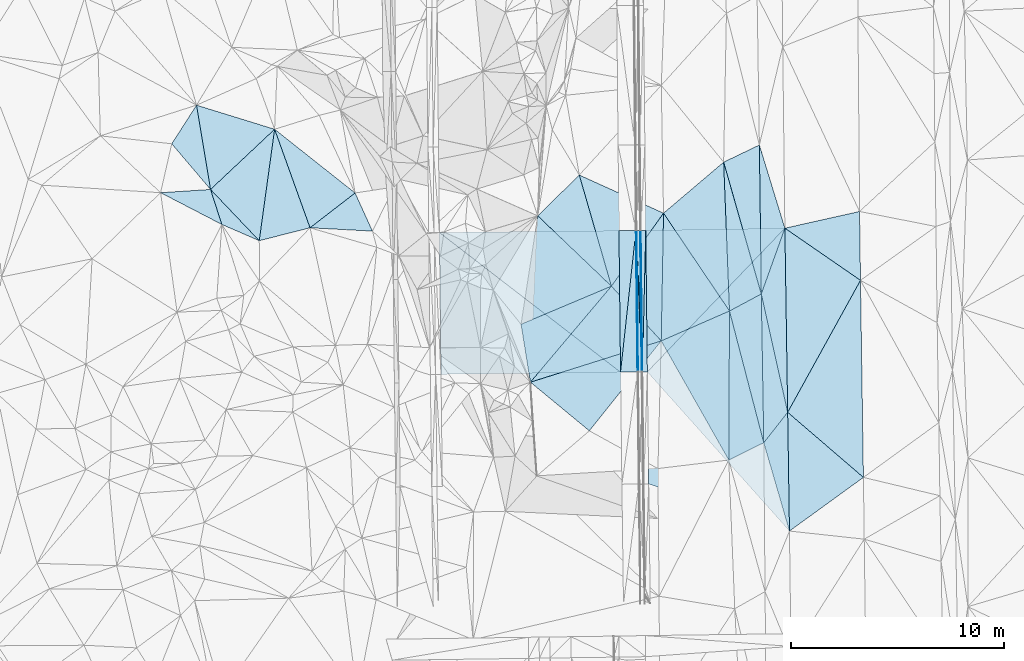
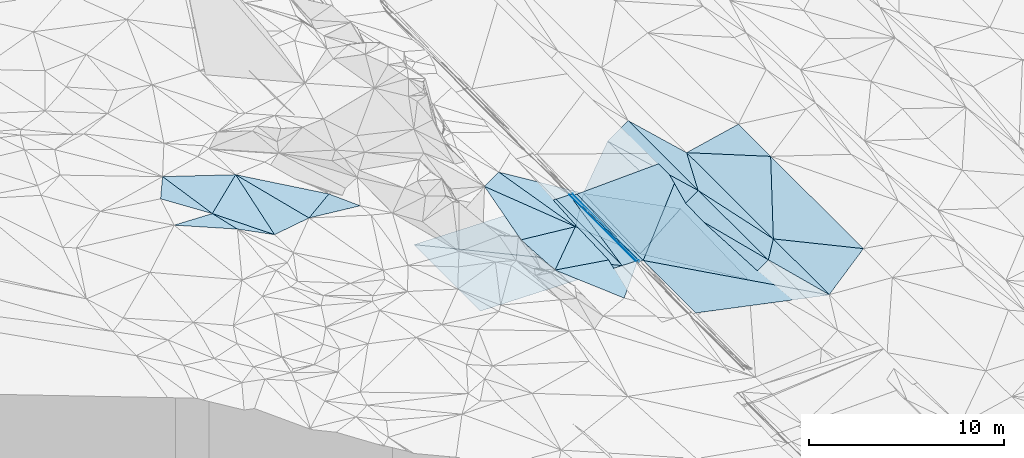
# One storey, part 16 of 275: 45 plates.
"""IFC2X3 building model written with IfcOpenShell, lengths in millimetres."""

from ifc_helpers import new_model, si_unit, frame, origin_with_axes, place, context, subcontext, project, spatial, polyline, outline, extrude, material, type_object, element, save


model = new_model("IFC2X3")

# Units and contexts
model_context = context("Model", 3, precision=1e-05, world=origin_with_axes())
body_context = subcontext(model_context, "Body", "Model", "MODEL_VIEW")
ifc_project = project(units=[si_unit("LENGTHUNIT", "METRE", prefix="MILLI"), si_unit("AREAUNIT", "SQUARE_METRE"), si_unit("VOLUMEUNIT", "CUBIC_METRE"), si_unit("MASSUNIT", "GRAM", prefix="KILO"), si_unit("TIMEUNIT", "SECOND"), si_unit("PLANEANGLEUNIT", "RADIAN"), si_unit("SOLIDANGLEUNIT", "STERADIAN"), si_unit("THERMODYNAMICTEMPERATUREUNIT", "DEGREE_CELSIUS"), si_unit("LUMINOUSINTENSITYUNIT", "LUMEN")], contexts=[model_context])

# Site, building, storey
site_placement = place(None, origin_with_axes())
site = spatial("IfcSite", under=ifc_project, at=site_placement, CompositionType="ELEMENT")
building_placement = place(site_placement, origin_with_axes())
building = spatial("IfcBuilding", under=site, at=building_placement, Name="Undefined", CompositionType="ELEMENT")
storey_placement = place(building_placement, origin_with_axes())
storey = spatial("IfcBuildingStorey", under=building, at=storey_placement, Name="Undefined", CompositionType="ELEMENT", Elevation=0.0)

# Plates
ifc_material = material()
plate_type_1 = type_object("IfcPlateType", PredefinedType="NOTDEFINED")
plate_1_placement = place(storey_placement, frame((-114015.364922591, 20772.4693420443, 46089.5039279863), z_axis=(-0.124564467724949, 0.0143597210554307, -0.99210760091414), x_axis=(-0.644770726207138, 0.758826841202952, 0.091937672889135)))
element("IfcPlate", 1, at=plate_1_placement, inside=storey, type_object=plate_type_1, material=ifc_material, Name="00", context=body_context, shape_type="SweptSolid", body=[
    extrude(outline(polyline([(0.0, 0.0), (2828.0029296875, 3.94356902688742e-09), (3443.91455078125, 2071.509765625), (0.0, 0.0)])), frame((-8.85201319254618e-08, 2.18876761149539e-07, -0.5000001331573), z_axis=(0.0, 0.0, 1.0), x_axis=(1.0, 0.0, 0.0)), (0.0, 0.0, 1.0), 1.0),
])
plate_type_2 = type_object("IfcPlateType", PredefinedType="NOTDEFINED")
plate_2_placement = place(storey_placement, frame((-93709.8882366682, 12193.5228893056, 41161.9217423104), z_axis=(-0.970128997320581, -0.00579860174768376, -0.242520318273614), x_axis=(-0.015702742113764, 0.999118731297531, 0.038925372965714)))
element("IfcPlate", 2, at=plate_2_placement, inside=storey, type_object=plate_type_2, material=ifc_material, Name="00_PR", context=body_context, shape_type="SweptSolid", body=[
    extrude(outline(polyline([(0.0, 0.0), (6661.51611328125, -4.67844074591994e-09), (6656.88037109375, 123.606216430664), (0.0, 0.0)])), frame((-8.85201319254618e-08, 2.18876761149539e-07, -0.5000001331573), z_axis=(0.0, 0.0, 1.0), x_axis=(1.0, 0.0, 0.0)), (0.0, 0.0, 1.0), 1.0),
])
plate_3_placement = place(storey_placement, frame((-93739.8481940446, 12192.151688232, 41281.9218577962), z_axis=(-0.970186715297732, -0.00580851785171614, -0.242289080604477), x_axis=(-0.0112096931076123, 0.999718314898496, 0.0209196949534378)))
element("IfcPlate", 3, at=plate_3_placement, inside=storey, type_object=plate_type_2, material=ifc_material, Name="00_PR", context=body_context, shape_type="SweptSolid", body=[
    extrude(outline(polyline([(0.0, 0.0), (6658.892578125, -9.24046617001295e-10), (-1.47539520263672, 123.682258605957), (0.0, 0.0)])), frame((-8.85201319254618e-08, 2.18876761149539e-07, -0.5000001331573), z_axis=(0.0, 0.0, 1.0), x_axis=(1.0, 0.0, 0.0)), (0.0, 0.0, 1.0), 1.0),
])
plate_type_3 = type_object("IfcPlateType", PredefinedType="NOTDEFINED")
plate_4_placement = place(storey_placement, frame((-94014.0067303804, 18847.0490866945, 41421.4452097669), z_axis=(-0.0202134344117027, 0.0206895906659804, -0.999581591420809), x_axis=(0.999743205173964, 0.0106622311027607, -0.0199960130126212)))
element("IfcPlate", 4, at=plate_4_placement, inside=storey, type_object=plate_type_3, material=ifc_material, Name="00_PR", context=body_context, shape_type="SweptSolid", body=[
    extrude(outline(polyline([(0.0, 0.0), (30.0059814453125, -3.63797880709171e-11), (36.4389686584473, 6659.0771484375), (0.0, 0.0)])), frame((-8.85201319254618e-08, 2.18876761149539e-07, -0.5000001331573), z_axis=(0.0, 0.0, 1.0), x_axis=(1.0, 0.0, 0.0)), (0.0, 0.0, 1.0), 1.0),
])
plate_5_placement = place(storey_placement, frame((-93909.3611444638, 12190.1645919995, 41281.5432118689), z_axis=(-0.020236435741365, 0.0206892206620344, -0.999581133683946), x_axis=(-0.999730993002964, -0.011751785107922, 0.0199959289877928)))
element("IfcPlate", 5, at=plate_5_placement, inside=storey, type_object=plate_type_3, material=ifc_material, Name="00_PR", context=body_context, shape_type="SweptSolid", body=[
    extrude(outline(polyline([(0.0, 0.0), (30.0061073303223, -1.96450855582953e-10), (29.184642791748, 6659.11279296875), (0.0, 0.0)])), frame((-8.85201319254618e-08, 2.18876761149539e-07, -0.5000001331573), z_axis=(0.0, 0.0, 1.0), x_axis=(1.0, 0.0, 0.0)), (0.0, 0.0, 1.0), 1.0),
])
plate_type_4 = type_object("IfcPlateType", PredefinedType="NOTDEFINED")
plate_6_placement = place(storey_placement, frame((-94739.3039393407, 12180.3996695704, 41298.1432095314), z_axis=(-0.020236435741365, 0.0206892206620344, -0.999581133683946), x_axis=(0.108138377913419, 0.993965859161828, 0.018383743986026)))
element("IfcPlate", 6, at=plate_6_placement, inside=storey, type_object=plate_type_4, material=ifc_material, Name="00_PR", context=body_context, shape_type="SweptSolid", body=[
    extrude(outline(polyline([(0.0, 0.0), (6707.12109375, -9.16770659387112e-10), (95.5660781860352, 794.432739257813), (0.0, 0.0)])), frame((-8.85201319254618e-08, 2.18876761149539e-07, -0.5000001331573), z_axis=(0.0, 0.0, 1.0), x_axis=(1.0, 0.0, 0.0)), (0.0, 0.0, 1.0), 1.0),
])
plate_7_placement = place(storey_placement, frame((-94014.0067303804, 18847.0490866945, 41421.4452097669), z_axis=(-0.0202142278372576, 0.0206867028955279, -0.999581635143551), x_axis=(-0.108138377915694, -0.993965859161573, -0.0183837439864522)))
element("IfcPlate", 7, at=plate_7_placement, inside=storey, type_object=plate_type_4, material=ifc_material, Name="00_PR", context=body_context, shape_type="SweptSolid", body=[
    extrude(outline(polyline([(0.0, 0.0), (6707.12109375, -9.16770659387112e-10), (94.6877517700195, 794.537475585938), (0.0, 0.0)])), frame((-8.85201319254618e-08, 2.18876761149539e-07, -0.5000001331573), z_axis=(0.0, 0.0, 1.0), x_axis=(1.0, 0.0, 0.0)), (0.0, 0.0, 1.0), 1.0),
])
plate_type_5 = type_object("IfcPlateType", PredefinedType="NOTDEFINED")
plate_8_placement = place(storey_placement, frame((-93554.0065118289, 18851.9525804362, 41308.3453783009), z_axis=(0.0324249764352489, 0.0212743317926748, -0.99924772889907), x_axis=(0.0112097451260177, -0.99971829535616, -0.0209206009565716)))
element("IfcPlate", 8, at=plate_8_placement, inside=storey, type_object=plate_type_5, material=ifc_material, Name="00_PR", context=body_context, shape_type="SweptSolid", body=[
    extrude(outline(polyline([(0.0, 0.0), (6658.60400390625, 7.02857505530119e-09), (6657.86962890625, 230.148956298828), (0.0, 0.0)])), frame((-8.85201319254618e-08, 2.18876761149539e-07, -0.5000001331573), z_axis=(0.0, 0.0, 1.0), x_axis=(1.0, 0.0, 0.0)), (0.0, 0.0, 1.0), 1.0),
])
plate_9_placement = place(storey_placement, frame((-93783.9955541894, 18849.688672733, 41300.845377649), z_axis=(0.0323763452633119, 0.0212755018201682, -0.999249280855228), x_axis=(0.999420342391402, 0.00983784111357759, 0.0325913500253779)))
element("IfcPlate", 9, at=plate_9_placement, inside=storey, type_object=plate_type_5, material=ifc_material, Name="00_PR", context=body_context, shape_type="SweptSolid", body=[
    extrude(outline(polyline([(0.0, 0.0), (230.122406005859, -9.27684595808387e-10), (4.54311275482178, 6658.0263671875), (0.0, 0.0)])), frame((-8.85201319254618e-08, 2.18876761149539e-07, -0.5000001331573), z_axis=(0.0, 0.0, 1.0), x_axis=(1.0, 0.0, 0.0)), (0.0, 0.0, 1.0), 1.0),
])
plate_type_6 = type_object("IfcPlateType", PredefinedType="NOTDEFINED")
plate_10_placement = place(storey_placement, frame((-111002.348097839, 23602.4211123626, 45749.5039753553), z_axis=(-0.125310474385731, 0.0142325221932643, -0.992015483912041), x_axis=(-0.726450165524312, -0.682312394449298, 0.0819753218387428)))
element("IfcPlate", 10, at=plate_10_placement, inside=storey, type_object=plate_type_6, material=ifc_material, Name="00", context=body_context, shape_type="SweptSolid", body=[
    extrude(outline(polyline([(0.0, 0.0), (4147.58984375, -1.83208612725139e-08), (1933.84606933594, 3354.2568359375), (0.0, 0.0)])), frame((-8.85201319254618e-08, 2.18876761149539e-07, -0.5000001331573), z_axis=(0.0, 0.0, 1.0), x_axis=(1.0, 0.0, 0.0)), (0.0, 0.0, 1.0), 1.0),
])
plate_type_7 = type_object("IfcPlateType", PredefinedType="NOTDEFINED")
plate_11_placement = place(storey_placement, frame((-89651.0841865646, 8051.67344498103, 41150.5160623505), z_axis=(0.250479311664303, 0.0229576087276333, -0.967849710765926), x_axis=(-0.490462221541969, 0.864940847921323, -0.106414937096531)))
element("IfcPlate", 11, at=plate_11_placement, inside=storey, type_object=plate_type_7, material=ifc_material, Name="00", context=body_context, shape_type="SweptSolid", body=[
    extrude(outline(polyline([(0.0, 0.0), (6474.65478515625, -1.96523615159094e-08), (6024.47998046875, 3580.78173828125), (0.0, 0.0)])), frame((-8.85201319254618e-08, 2.18876761149539e-07, -0.5000001331573), z_axis=(0.0, 0.0, 1.0), x_axis=(1.0, 0.0, 0.0)), (0.0, 0.0, 1.0), 1.0),
])
plate_type_8 = type_object("IfcPlateType", PredefinedType="NOTDEFINED")
plate_12_placement = place(storey_placement, frame((-94739.3039393407, 12180.3996695704, 41298.1432095314), z_axis=(-0.0202365669105856, 0.0206577431224442, -0.999581782051254), x_axis=(-0.999730851009232, -0.0117629081194409, 0.0199964880149204)))
element("IfcPlate", 12, at=plate_12_placement, inside=storey, type_object=plate_type_8, material=ifc_material, Name="00_PR", context=body_context, shape_type="SweptSolid", body=[
    extrude(outline(polyline([(0.0, 0.0), (8444.1826171875, 4.79940354125574e-08), (8443.1376953125, 6669.33447265625), (0.0, 0.0)])), frame((-8.85201319254618e-08, 2.18876761149539e-07, -0.5000001331573), z_axis=(0.0, 0.0, 1.0), x_axis=(1.0, 0.0, 0.0)), (0.0, 0.0, 1.0), 1.0),
])
plate_type_9 = type_object("IfcPlateType", PredefinedType="NOTDEFINED")
plate_13_placement = place(storey_placement, frame((-103255.832350594, 18748.533567026, 41606.3002094753), z_axis=(-0.0202142278372576, 0.0206867028955279, -0.999581635143551), x_axis=(0.99974324254313, 0.0106569761117896, -0.0199969460043807)))
element("IfcPlate", 13, at=plate_13_placement, inside=storey, type_object=plate_type_9, material=ifc_material, Name="00_PR", context=body_context, shape_type="SweptSolid", body=[
    extrude(outline(polyline([(0.0, 0.0), (8444.0390625, 5.16338332090527e-08), (8450.5078125, 6659.994140625), (0.0, 0.0)])), frame((-8.85201319254618e-08, 2.18876761149539e-07, -0.5000001331573), z_axis=(0.0, 0.0, 1.0), x_axis=(1.0, 0.0, 0.0)), (0.0, 0.0, 1.0), 1.0),
])
plate_type_10 = type_object("IfcPlateType", PredefinedType="NOTDEFINED")
plate_14_placement = place(storey_placement, frame((-93739.3632111408, 12192.1650490318, 41281.543111635), z_axis=(-0.000223052062595147, 0.0209185094404313, -0.999781159159627), x_axis=(-0.0367256471119653, 0.999106546124247, 0.0209125879767624)))
element("IfcPlate", 14, at=plate_14_placement, inside=storey, type_object=plate_type_10, material=ifc_material, Name="00_PR", context=body_context, shape_type="SweptSolid", body=[
    extrude(outline(polyline([(0.0, 0.0), (6661.15576171875, 1.97906047105789e-09), (6656.7236328125, 169.942993164063), (0.0, 0.0)])), frame((-8.85201319254618e-08, 2.18876761149539e-07, -0.5000001331573), z_axis=(0.0, 0.0, 1.0), x_axis=(1.0, 0.0, 0.0)), (0.0, 0.0, 1.0), 1.0),
])
plate_15_placement = place(storey_placement, frame((-93739.3632111408, 12192.1650490318, 41281.543111635), z_axis=(-0.000246149900615018, 0.0209176607376323, -0.999781171496789), x_axis=(-0.999930769399473, -0.0117667501111672, -2.73062899398761e-11)))
element("IfcPlate", 15, at=plate_15_placement, inside=storey, type_object=plate_type_10, material=ifc_material, Name="00_PR", context=body_context, shape_type="SweptSolid", body=[
    extrude(outline(polyline([(0.0, 0.0), (169.999694824219, 9.24046617001295e-10), (166.308197021484, 6659.0791015625), (0.0, 0.0)])), frame((-8.85201319254618e-08, 2.18876761149539e-07, -0.5000001331573), z_axis=(0.0, 0.0, 1.0), x_axis=(1.0, 0.0, 0.0)), (0.0, 0.0, 1.0), 1.0),
])
plate_type_11 = type_object("IfcPlateType", PredefinedType="NOTDEFINED")
plate_16_placement = place(storey_placement, frame((-87013.0404522369, 18951.1289030204, 41504.7893355039), z_axis=(0.0295354950647093, 0.0213940997876386, -0.999334752235486), x_axis=(0.0151458611024018, -0.999665720009021, -0.0209535469625894)))
element("IfcPlate", 16, at=plate_16_placement, inside=storey, type_object=plate_type_11, material=ifc_material, Name="00_PR", context=body_context, shape_type="SweptSolid", body=[
    extrude(outline(polyline([(0.0, 0.0), (14243.4111328125, -2.19733919948339e-08), (6662.7431640625, 6570.85986328125), (0.0, 0.0)])), frame((-8.85201319254618e-08, 2.18876761149539e-07, -0.5000001331573), z_axis=(0.0, 0.0, 1.0), x_axis=(1.0, 0.0, 0.0)), (0.0, 0.0, 1.0), 1.0),
])
plate_type_12 = type_object("IfcPlateType", PredefinedType="NOTDEFINED")
plate_17_placement = place(storey_placement, frame((-93479.3666279764, 12195.2243472875, 41169.0433354008), z_axis=(0.0296907128012462, 0.0212454639890268, -0.99933332368797), x_axis=(-0.0112096931076123, 0.999718314898496, 0.0209196949534378)))
element("IfcPlate", 17, at=plate_17_placement, inside=storey, type_object=plate_type_12, material=ifc_material, Name="00_PR", context=body_context, shape_type="SweptSolid", body=[
    extrude(outline(polyline([(0.0, 0.0), (6658.60400390625, 7.02857505530119e-09), (6688.53955078125, 6544.599609375), (0.0, 0.0)])), frame((-8.85201319254618e-08, 2.18876761149539e-07, -0.5000001331573), z_axis=(0.0, 0.0, 1.0), x_axis=(1.0, 0.0, 0.0)), (0.0, 0.0, 1.0), 1.0),
])
plate_type_13 = type_object("IfcPlateType", PredefinedType="NOTDEFINED")
plate_18_placement = place(storey_placement, frame((-93415.0808870992, 6927.62469651798, 41057.7553368161), z_axis=(0.0296252686250594, 0.0214742890478554, -0.999330374985561), x_axis=(-0.0122003671088008, 0.999702491309, 0.0211206039920612)))
element("IfcPlate", 18, at=plate_18_placement, inside=storey, type_object=plate_type_13, material=ifc_material, Name="00_PR", context=body_context, shape_type="SweptSolid", body=[
    extrude(outline(polyline([(0.0, 0.0), (5269.16748046875, -2.53203324973583e-09), (-2292.087890625, 6593.18994140625), (0.0, 0.0)])), frame((-8.85201319254618e-08, 2.18876761149539e-07, -0.5000001331573), z_axis=(0.0, 0.0, 1.0), x_axis=(1.0, 0.0, 0.0)), (0.0, 0.0, 1.0), 1.0),
])
plate_type_14 = type_object("IfcPlateType", PredefinedType="NOTDEFINED")
plate_19_placement = place(storey_placement, frame((-86797.3205871521, 4712.47970274039, 41229.5001540059), z_axis=(0.0119350155504829, 0.0234593980078428, -0.999653546009276), x_axis=(-0.279280289702698, 0.960017748063137, 0.0191948739865551)))
element("IfcPlate", 19, at=plate_19_placement, inside=storey, type_object=plate_type_14, material=ifc_material, Name="00", context=body_context, shape_type="SweptSolid", body=[
    extrude(outline(polyline([(0.0, 0.0), (4324.07080078125, 8.51287040859461e-09), (5385.4365234375, 1478.50366210938), (0.0, 0.0)])), frame((-8.85201319254618e-08, 2.18876761149539e-07, -0.5000001331573), z_axis=(0.0, 0.0, 1.0), x_axis=(1.0, 0.0, 0.0)), (0.0, 0.0, 1.0), 1.0),
])
plate_type_15 = type_object("IfcPlateType", PredefinedType="NOTDEFINED")
plate_20_placement = place(storey_placement, frame((-107217.945086848, 20606.8394973865, 45039.5059583901), z_axis=(-0.145820569838406, 0.0499630264308973, -0.988048610849622), x_axis=(-0.788547585721034, -0.608989631611722, 0.0855823208551132)))
element("IfcPlate", 20, at=plate_20_placement, inside=storey, type_object=plate_type_15, material=ifc_material, Name="00", context=body_context, shape_type="SweptSolid", body=[
    extrude(outline(polyline([(0.0, 0.0), (2687.47094726563, 1.18452589958906e-08), (1220.66430664063, 4723.291015625), (0.0, 0.0)])), frame((-8.85201319254618e-08, 2.18876761149539e-07, -0.5000001331573), z_axis=(0.0, 0.0, 1.0), x_axis=(1.0, 0.0, 0.0)), (0.0, 0.0, 1.0), 1.0),
])
plate_type_16 = type_object("IfcPlateType", PredefinedType="NOTDEFINED")
plate_21_placement = place(storey_placement, frame((-96206.2262594341, 9424.53063963242, 41449.5385213398), z_axis=(-0.375590630794114, 0.084537170147736, -0.922922068716039), x_axis=(-0.722938962095539, 0.596384706328646, 0.34883311072993)))
element("IfcPlate", 21, at=plate_21_placement, inside=storey, type_object=plate_type_16, material=ifc_material, Name="00", context=body_context, shape_type="SweptSolid", body=[
    extrude(outline(polyline([(0.0, 0.0), (3832.7783203125, -1.18816387839615e-08), (-266.50537109375, 5495.00830078125), (0.0, 0.0)])), frame((-8.85201319254618e-08, 2.18876761149539e-07, -0.5000001331573), z_axis=(0.0, 0.0, 1.0), x_axis=(1.0, 0.0, 0.0)), (0.0, 0.0, 1.0), 1.0),
])
plate_type_17 = type_object("IfcPlateType", PredefinedType="NOTDEFINED")
plate_22_placement = place(storey_placement, frame((-88121.3741260911, 15858.9301005727, 41451.5002949508), z_axis=(0.0280348312334138, 0.0216242980177762, -0.999373022436043), x_axis=(-0.0129219826705515, 0.99969028505794, 0.0212686700251194)))
element("IfcPlate", 22, at=plate_22_placement, inside=storey, type_object=plate_type_17, material=ifc_material, Name="00", context=body_context, shape_type="SweptSolid", body=[
    extrude(outline(polyline([(0.0, 0.0), (7005.609375, 2.8085196390748e-09), (3079.00366210938, 1148.66711425781), (0.0, 0.0)])), frame((-8.85201319254618e-08, 2.18876761149539e-07, -0.5000001331573), z_axis=(0.0, 0.0, 1.0), x_axis=(1.0, 0.0, 0.0)), (0.0, 0.0, 1.0), 1.0),
])
plate_type_18 = type_object("IfcPlateType", PredefinedType="NOTDEFINED")
plate_23_placement = place(storey_placement, frame((-88121.3493018186, 15858.9251591015, 41451.5015304697), z_axis=(0.0776922434328477, 0.0117340601776445, -0.996908334372884), x_axis=(-0.879079468215501, -0.470888081742311, -0.0740520292429455)))
element("IfcPlate", 23, at=plate_23_placement, inside=storey, type_object=plate_type_18, material=ifc_material, Name="00", context=body_context, shape_type="SweptSolid", body=[
    extrude(outline(polyline([(0.0, 0.0), (1701.50634765625, 2.16095941141248e-09), (-1357.48303222656, 6301.08642578125), (0.0, 0.0)])), frame((-8.85201319254618e-08, 2.18876761149539e-07, -0.5000001331573), z_axis=(0.0, 0.0, 1.0), x_axis=(1.0, 0.0, 0.0)), (0.0, 0.0, 1.0), 1.0),
])
plate_type_19 = type_object("IfcPlateType", PredefinedType="NOTDEFINED")
plate_24_placement = place(storey_placement, frame((-111002.327953445, 23602.4502040437, 45749.5031065872), z_axis=(-0.0849977779939664, 0.0724181837867888, -0.993745935535392), x_axis=(0.336692229542888, -0.936599843794806, -0.097051919965468)))
element("IfcPlate", 24, at=plate_24_placement, inside=storey, type_object=plate_type_19, material=ifc_material, Name="00", context=body_context, shape_type="SweptSolid", body=[
    extrude(outline(polyline([(0.0, 0.0), (4945.80615234375, 9.80799086391926e-09), (4695.2099609375, 2456.78686523438), (0.0, 0.0)])), frame((-8.85201319254618e-08, 2.18876761149539e-07, -0.5000001331573), z_axis=(0.0, 0.0, 1.0), x_axis=(1.0, 0.0, 0.0)), (0.0, 0.0, 1.0), 1.0),
])
plate_type_20 = type_object("IfcPlateType", PredefinedType="NOTDEFINED")
plate_25_placement = place(storey_placement, frame((-88004.9113834452, 8863.66510691612, 41312.5019860086), z_axis=(0.0859466234091415, 0.0244606701403055, -0.995999424468134), x_axis=(-0.893368457816508, -0.440640745580413, -0.0879120692106214)))
element("IfcPlate", 25, at=plate_25_placement, inside=storey, type_object=plate_type_20, material=ifc_material, Name="00", context=body_context, shape_type="SweptSolid", body=[
    extrude(outline(polyline([(0.0, 0.0), (1842.75036621094, -1.01863406598568e-08), (-1290.2099609375, 6269.04443359375), (0.0, 0.0)])), frame((-8.85201319254618e-08, 2.18876761149539e-07, -0.5000001331573), z_axis=(0.0, 0.0, 1.0), x_axis=(1.0, 0.0, 0.0)), (0.0, 0.0, 1.0), 1.0),
])
plate_type_21 = type_object("IfcPlateType", PredefinedType="NOTDEFINED")
plate_26_placement = place(storey_placement, frame((-88121.375108886, 15858.930454088, 41451.500275696), z_axis=(0.026063473322201, 0.0223320876886312, -0.999410813038287), x_axis=(0.337259630403384, 0.940939242302108, 0.0298208651133506)))
element("IfcPlate", 26, at=plate_26_placement, inside=storey, type_object=plate_type_21, material=ifc_material, Name="00", context=body_context, shape_type="SweptSolid", body=[
    extrude(outline(polyline([(0.0, 0.0), (3286.28979492188, -4.72937244921923e-09), (-4819.9765625, 3044.64184570313), (0.0, 0.0)])), frame((-8.85201319254618e-08, 2.18876761149539e-07, -0.5000001331573), z_axis=(0.0, 0.0, 1.0), x_axis=(1.0, 0.0, 0.0)), (0.0, 0.0, 1.0), 1.0),
])
plate_type_22 = type_object("IfcPlateType", PredefinedType="NOTDEFINED")
plate_27_placement = place(storey_placement, frame((-88121.3517738476, 15858.9297965276, 41451.501422941), z_axis=(0.072734538703185, 0.0210241869998504, -0.997129715955066), x_axis=(0.0166390645360846, -0.999664226973011, -0.0198639080197159)))
element("IfcPlate", 27, at=plate_27_placement, inside=storey, type_object=plate_type_22, material=ifc_material, Name="00", context=body_context, shape_type="SweptSolid", body=[
    extrude(outline(polyline([(0.0, 0.0), (6997.6162109375, 2.83762346953154e-09), (778.564880371094, 1512.93115234375), (0.0, 0.0)])), frame((-8.85201319254618e-08, 2.18876761149539e-07, -0.5000001331573), z_axis=(0.0, 0.0, 1.0), x_axis=(1.0, 0.0, 0.0)), (0.0, 0.0, 1.0), 1.0),
])
plate_type_23 = type_object("IfcPlateType", PredefinedType="NOTDEFINED")
plate_28_placement = place(storey_placement, frame((-86881.8009424597, 10295.027879298, 41359.5001477814), z_axis=(0.0161745826846271, 0.0201331725495481, -0.999666463495734), x_axis=(-0.617106294349018, -0.78645594123266, -0.0258239031649945)))
element("IfcPlate", 28, at=plate_28_placement, inside=storey, type_object=plate_type_23, material=ifc_material, Name="00", context=body_context, shape_type="SweptSolid", body=[
    extrude(outline(polyline([(0.0, 0.0), (1820.01928710938, 8.73114913702011e-10), (-3613.18701171875, 4409.86376953125), (0.0, 0.0)])), frame((-8.85201319254618e-08, 2.18876761149539e-07, -0.5000001331573), z_axis=(0.0, 0.0, 1.0), x_axis=(1.0, 0.0, 0.0)), (0.0, 0.0, 1.0), 1.0),
])
plate_type_24 = type_object("IfcPlateType", PredefinedType="NOTDEFINED")
plate_29_placement = place(storey_placement, frame((-87013.0474261755, 18951.1275936233, 41549.5001311001), z_axis=(0.0157299033352284, 0.0187291637091391, -0.999700849538411), x_axis=(0.97560359415009, 0.218676514702192, 0.0194475962300726)))
element("IfcPlate", 29, at=plate_29_placement, inside=storey, type_object=plate_type_24, material=ifc_material, Name="00", context=body_context, shape_type="SweptSolid", body=[
    extrude(outline(polyline([(0.0, 0.0), (3599.41650390625, -4.37285052612424e-09), (2932.28076171875, 3170.46215820313), (0.0, 0.0)])), frame((-8.85201319254618e-08, 2.18876761149539e-07, -0.5000001331573), z_axis=(0.0, 0.0, 1.0), x_axis=(1.0, 0.0, 0.0)), (0.0, 0.0, 1.0), 1.0),
])
plate_type_25 = type_object("IfcPlateType", PredefinedType="NOTDEFINED")
plate_30_placement = place(storey_placement, frame((-89891.403278974, 22056.4354794082, 41386.5034691698), z_axis=(0.115671936956676, 0.0226221410664177, -0.993029829226827), x_axis=(0.895684434434708, 0.429796604342422, 0.114123936170725)))
element("IfcPlate", 30, at=plate_30_placement, inside=storey, type_object=plate_type_25, material=ifc_material, Name="00", context=body_context, shape_type="SweptSolid", body=[
    extrude(outline(polyline([(0.0, 0.0), (1875.15441894531, -7.79255060479045e-09), (-1070.82165527344, 6356.0830078125), (0.0, 0.0)])), frame((-8.85201319254618e-08, 2.18876761149539e-07, -0.5000001331573), z_axis=(0.0, 0.0, 1.0), x_axis=(1.0, 0.0, 0.0)), (0.0, 0.0, 1.0), 1.0),
])
plate_type_26 = type_object("IfcPlateType", PredefinedType="NOTDEFINED")
plate_31_placement = place(storey_placement, frame((-106403.053645933, 18813.0947670287, 45099.5018477772), z_axis=(-0.0609912074153087, -0.0610333485306731, -0.996270547083048), x_axis=(-0.996903389693979, 0.0533600673207104, 0.0577610148126238)))
element("IfcPlate", 31, at=plate_31_placement, inside=storey, type_object=plate_type_26, material=ifc_material, Name="00", context=body_context, shape_type="SweptSolid", body=[
    extrude(outline(polyline([(0.0, 0.0), (2943.16162109375, -5.07679942529649e-09), (904.571472167969, 1751.18542480469), (0.0, 0.0)])), frame((-8.85201319254618e-08, 2.18876761149539e-07, -0.5000001331573), z_axis=(0.0, 0.0, 1.0), x_axis=(1.0, 0.0, 0.0)), (0.0, 0.0, 1.0), 1.0),
])
plate_type_27 = type_object("IfcPlateType", PredefinedType="NOTDEFINED")
plate_32_placement = place(storey_placement, frame((-92718.1033973239, 19657.7433577946, 40584.533281202), z_axis=(-0.357908021978965, 0.0256033117666956, -0.933405762907902), x_axis=(-0.0181185844080019, -0.999626231227913, -0.0204722920096796)))
element("IfcPlate", 32, at=plate_32_placement, inside=storey, type_object=plate_type_27, material=ifc_material, Name="00", context=body_context, shape_type="SweptSolid", body=[
    extrude(outline(polyline([(0.0, 0.0), (6008.12060546875, -8.41100700199604e-09), (3458.24438476563, 2556.39501953125), (0.0, 0.0)])), frame((-8.85201319254618e-08, 2.18876761149539e-07, -0.5000001331573), z_axis=(0.0, 0.0, 1.0), x_axis=(1.0, 0.0, 0.0)), (0.0, 0.0, 1.0), 1.0),
])
plate_type_28 = type_object("IfcPlateType", PredefinedType="NOTDEFINED")
plate_33_placement = place(storey_placement, frame((-89617.0183154727, 15057.7094790827, 41325.5170455467), z_axis=(0.258328048490908, 0.0185436003383293, -0.965879264840783), x_axis=(-0.554026690262537, 0.821903548379661, -0.132397068085596)))
element("IfcPlate", 33, at=plate_33_placement, inside=storey, type_object=plate_type_28, material=ifc_material, Name="00", context=body_context, shape_type="SweptSolid", body=[
    extrude(outline(polyline([(0.0, 0.0), (5596.80078125, -4.55474946647882e-09), (5896.1767578125, 3781.0322265625), (0.0, 0.0)])), frame((-8.85201319254618e-08, 2.18876761149539e-07, -0.5000001331573), z_axis=(0.0, 0.0, 1.0), x_axis=(1.0, 0.0, 0.0)), (0.0, 0.0, 1.0), 1.0),
])
plate_type_29 = type_object("IfcPlateType", PredefinedType="NOTDEFINED")
plate_34_placement = place(storey_placement, frame((-111725.442777184, 18362.6496287326, 45429.5110954515), z_axis=(-0.191201587779741, 0.0860978443292065, -0.977767413055053), x_axis=(-0.675655969427072, 0.711032736600749, 0.194734327892166)))
element("IfcPlate", 34, at=plate_34_placement, inside=storey, type_object=plate_type_29, material=ifc_material, Name="00", context=body_context, shape_type="SweptSolid", body=[
    extrude(outline(polyline([(0.0, 0.0), (3389.23291015625, -1.00117176771164e-08), (3299.44873046875, 4146.61767578125), (0.0, 0.0)])), frame((-8.85201319254618e-08, 2.18876761149539e-07, -0.5000001331573), z_axis=(0.0, 0.0, 1.0), x_axis=(1.0, 0.0, 0.0)), (0.0, 0.0, 1.0), 1.0),
])
plate_type_30 = type_object("IfcPlateType", PredefinedType="NOTDEFINED")
plate_35_placement = place(storey_placement, frame((-99416.0715277124, 14434.4538865752, 43179.5426739596), z_axis=(-0.40040265105901, 0.0561787773948768, -0.914615581539771), x_axis=(0.151955801493449, 0.988370186424561, -0.00581454895612256)))
element("IfcPlate", 35, at=plate_35_placement, inside=storey, type_object=plate_type_30, material=ifc_material, Name="00", context=body_context, shape_type="SweptSolid", body=[
    extrude(outline(polyline([(0.0, 0.0), (5159.4716796875, 3.14321368932724e-09), (2425.81616210938, 4293.7646484375), (0.0, 0.0)])), frame((-8.85201319254618e-08, 2.18876761149539e-07, -0.5000001331573), z_axis=(0.0, 0.0, 1.0), x_axis=(1.0, 0.0, 0.0)), (0.0, 0.0, 1.0), 1.0),
])
plate_type_31 = type_object("IfcPlateType", PredefinedType="NOTDEFINED")
plate_36_placement = place(storey_placement, frame((-96679.1161294818, 21450.2003590549, 42199.5347679505), z_axis=(-0.365114509286352, 0.031478078270779, -0.93043029061664), x_axis=(0.854040512209739, -0.386474337367601, -0.348213138839994)))
element("IfcPlate", 36, at=plate_36_placement, inside=storey, type_object=plate_type_31, material=ifc_material, Name="00", context=body_context, shape_type="SweptSolid", body=[
    extrude(outline(polyline([(0.0, 0.0), (4637.9638671875, 1.98415364138782e-08), (3578.509765625, 4167.9931640625), (0.0, 0.0)])), frame((-8.85201319254618e-08, 2.18876761149539e-07, -0.5000001331573), z_axis=(0.0, 0.0, 1.0), x_axis=(1.0, 0.0, 0.0)), (0.0, 0.0, 1.0), 1.0),
])
plate_type_32 = type_object("IfcPlateType", PredefinedType="NOTDEFINED")
plate_37_placement = place(storey_placement, frame((-95167.4053676016, 16225.2835189879, 41429.5512619631), z_axis=(-0.441104508611206, 0.00463023558593048, -0.89744379957816), x_axis=(-0.680667041685208, 0.650007227723022, 0.337909725032203)))
element("IfcPlate", 37, at=plate_37_placement, inside=storey, type_object=plate_type_32, material=ifc_material, Name="00", context=body_context, shape_type="SweptSolid", body=[
    extrude(outline(polyline([(0.0, 0.0), (5090.11669921875, -3.49245965480804e-10), (4685.4130859375, 2867.89208984375), (0.0, 0.0)])), frame((-8.85201319254618e-08, 2.18876761149539e-07, -0.5000001331573), z_axis=(0.0, 0.0, 1.0), x_axis=(1.0, 0.0, 0.0)), (0.0, 0.0, 1.0), 1.0),
])
plate_type_33 = type_object("IfcPlateType", PredefinedType="NOTDEFINED")
plate_38_placement = place(storey_placement, frame((-95167.3648076682, 16225.29292182, 41429.5336519483), z_axis=(-0.359984225277807, 0.0234360864181363, -0.932663984189665), x_axis=(0.648188289399184, -0.712725662428457, -0.268093400891699)))
element("IfcPlate", 38, at=plate_38_placement, inside=storey, type_object=plate_type_33, material=ifc_material, Name="00", context=body_context, shape_type="SweptSolid", body=[
    extrude(outline(polyline([(0.0, 0.0), (3610.68188476563, 1.43845682032406e-08), (384.726226806641, 6049.169921875), (0.0, 0.0)])), frame((-8.85201319254618e-08, 2.18876761149539e-07, -0.5000001331573), z_axis=(0.0, 0.0, 1.0), x_axis=(1.0, 0.0, 0.0)), (0.0, 0.0, 1.0), 1.0),
])
plate_type_34 = type_object("IfcPlateType", PredefinedType="NOTDEFINED")
plate_39_placement = place(storey_placement, frame((-98977.1051968293, 11710.3320469006, 42786.5437859244), z_axis=(-0.403860257984848, 0.0665498387505829, -0.912396849502826), x_axis=(-0.15749907959723, 0.977400297429753, 0.141006022957378)))
element("IfcPlate", 39, at=plate_39_placement, inside=storey, type_object=plate_type_34, material=ifc_material, Name="00", context=body_context, shape_type="SweptSolid", body=[
    extrude(outline(polyline([(0.0, 0.0), (2787.11499023438, -5.67524693906307e-09), (3621.57275390625, 4860.5224609375), (0.0, 0.0)])), frame((-8.85201319254618e-08, 2.18876761149539e-07, -0.5000001331573), z_axis=(0.0, 0.0, 1.0), x_axis=(1.0, 0.0, 0.0)), (0.0, 0.0, 1.0), 1.0),
])
plate_type_35 = type_object("IfcPlateType", PredefinedType="NOTDEFINED")
plate_40_placement = place(storey_placement, frame((-113484.503397869, 19126.5906208699, 45929.502992228), z_axis=(-0.0849088522498095, 0.069240665737953, -0.993979988238086), x_axis=(-0.882632511886365, 0.457658543185839, 0.107277708822389)))
element("IfcPlate", 40, at=plate_40_placement, inside=storey, type_object=plate_type_35, material=ifc_material, Name="00", context=body_context, shape_type="SweptSolid", body=[
    extrude(outline(polyline([(0.0, 0.0), (3262.56030273438, 1.85609678737819e-08), (1238.96557617188, 1217.11303710938), (0.0, 0.0)])), frame((-8.85201319254618e-08, 2.18876761149539e-07, -0.5000001331573), z_axis=(0.0, 0.0, 1.0), x_axis=(1.0, 0.0, 0.0)), (0.0, 0.0, 1.0), 1.0),
])
plate_type_36 = type_object("IfcPlateType", PredefinedType="NOTDEFINED")
plate_41_placement = place(storey_placement, frame((-111725.482616687, 18362.6096810181, 45429.5186899372), z_axis=(-0.270906937857924, 0.00620022783332447, -0.962585574479099), x_axis=(-0.887570097821837, 0.385454693193528, 0.252277626728208)))
element("IfcPlate", 41, at=plate_41_placement, inside=storey, type_object=plate_type_36, material=ifc_material, Name="00", context=body_context, shape_type="SweptSolid", body=[
    extrude(outline(polyline([(0.0, 0.0), (1981.94348144531, -2.53930920735002e-09), (3127.88940429688, 1305.07006835938), (0.0, 0.0)])), frame((-8.85201319254618e-08, 2.18876761149539e-07, -0.5000001331573), z_axis=(0.0, 0.0, 1.0), x_axis=(1.0, 0.0, 0.0)), (0.0, 0.0, 1.0), 1.0),
])
plate_type_37 = type_object("IfcPlateType", PredefinedType="NOTDEFINED")
plate_42_placement = place(storey_placement, frame((-83458.0492856312, 16499.1913375952, 41559.5001897777), z_axis=(0.018784194076798, 0.0218570253293485, -0.999584625980531), x_axis=(0.014907783661682, -0.999656005311055, -0.0215784390501253)))
element("IfcPlate", 42, at=plate_42_placement, inside=storey, type_object=plate_type_37, material=ifc_material, Name="00", context=body_context, shape_type="SweptSolid", body=[
    extrude(outline(polyline([(0.0, 0.0), (9268.5107421875, -6.98491930961609e-10), (6155.3037109375, 3516.52368164063), (0.0, 0.0)])), frame((-8.85201319254618e-08, 2.18876761149539e-07, -0.5000001331573), z_axis=(0.0, 0.0, 1.0), x_axis=(1.0, 0.0, 0.0)), (0.0, 0.0, 1.0), 1.0),
])
plate_type_38 = type_object("IfcPlateType", PredefinedType="NOTDEFINED")
plate_43_placement = place(storey_placement, frame((-86797.316419647, 4712.47976458686, 41229.5002227482), z_axis=(0.0202669118720077, 0.0235822954445536, -0.999516446900569), x_axis=(-0.0151274806584669, 0.99961457565566, 0.0232778750250597)))
element("IfcPlate", 43, at=plate_43_placement, inside=storey, type_object=plate_type_38, material=ifc_material, Name="00", context=body_context, shape_type="SweptSolid", body=[
    extrude(outline(polyline([(0.0, 0.0), (5584.7021484375, 9.31322574615479e-10), (2470.8388671875, 3515.94287109375), (0.0, 0.0)])), frame((-8.85201319254618e-08, 2.18876761149539e-07, -0.5000001331573), z_axis=(0.0, 0.0, 1.0), x_axis=(1.0, 0.0, 0.0)), (0.0, 0.0, 1.0), 1.0),
])
plate_type_39 = type_object("IfcPlateType", PredefinedType="NOTDEFINED")
plate_44_placement = place(storey_placement, frame((-87013.0462265273, 18951.1293448727, 41549.5001911602), z_axis=(0.0181343549231466, 0.0222157682745402, -0.999588717829235), x_axis=(0.823187200137843, -0.567765331476784, 0.00231557817310278)))
element("IfcPlate", 44, at=plate_44_placement, inside=storey, type_object=plate_type_39, material=ifc_material, Name="00", context=body_context, shape_type="SweptSolid", body=[
    extrude(outline(polyline([(0.0, 0.0), (4318.576171875, 1.02081685326993e-08), (5022.23388671875, 7053.97509765625), (0.0, 0.0)])), frame((-8.85201319254618e-08, 2.18876761149539e-07, -0.5000001331573), z_axis=(0.0, 0.0, 1.0), x_axis=(1.0, 0.0, 0.0)), (0.0, 0.0, 1.0), 1.0),
])
plate_type_40 = type_object("IfcPlateType", PredefinedType="NOTDEFINED")
plate_45_placement = place(storey_placement, frame((-89617.0206294048, 15057.7078089043, 41325.5164010368), z_axis=(0.25368913846697, 0.0152093062494574, -0.96716622047469), x_axis=(-0.889349773780105, -0.389541927543022, -0.239403564224393)))
element("IfcPlate", 45, at=plate_45_placement, inside=storey, type_object=plate_type_40, material=ifc_material, Name="00", context=body_context, shape_type="SweptSolid", body=[
    extrude(outline(polyline([(0.0, 0.0), (3608.96875, 1.78988557308912e-08), (1143.16870117188, 5478.80859375), (0.0, 0.0)])), frame((-8.85201319254618e-08, 2.18876761149539e-07, -0.5000001331573), z_axis=(0.0, 0.0, 1.0), x_axis=(1.0, 0.0, 0.0)), (0.0, 0.0, 1.0), 1.0),
])

save(model, "model.ifc")
